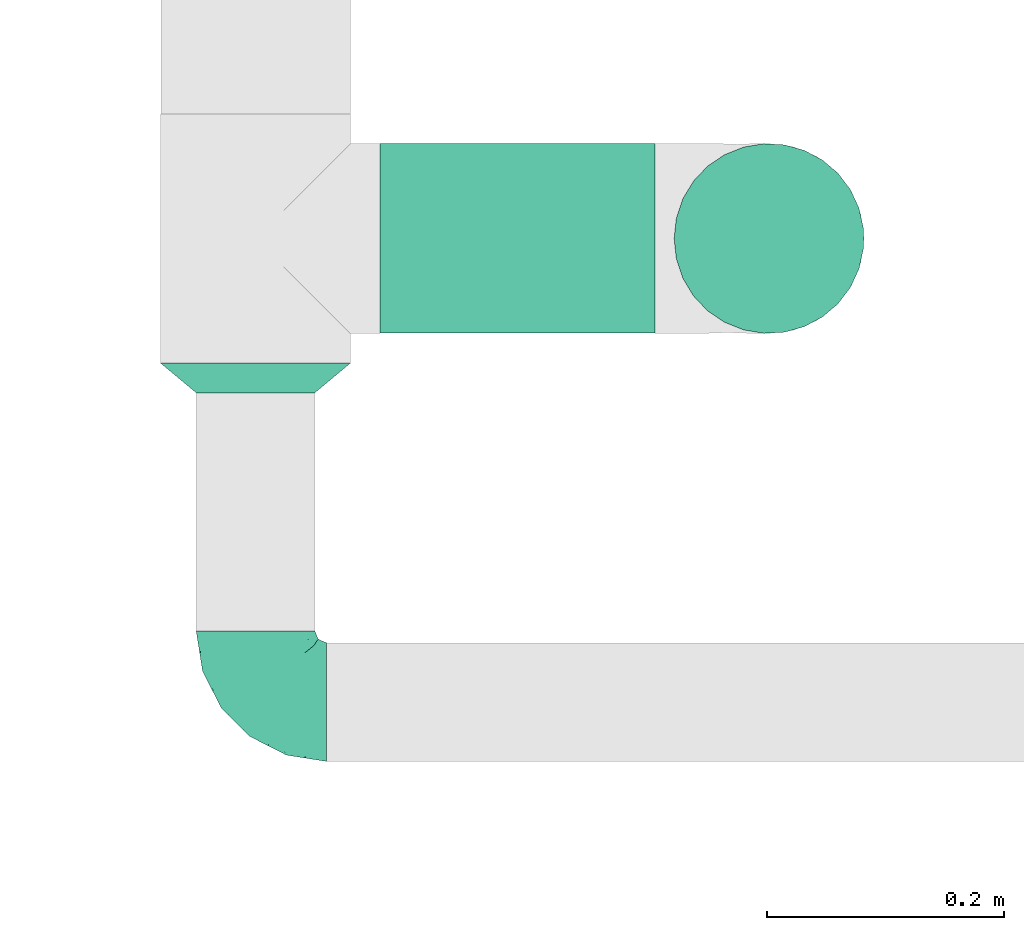
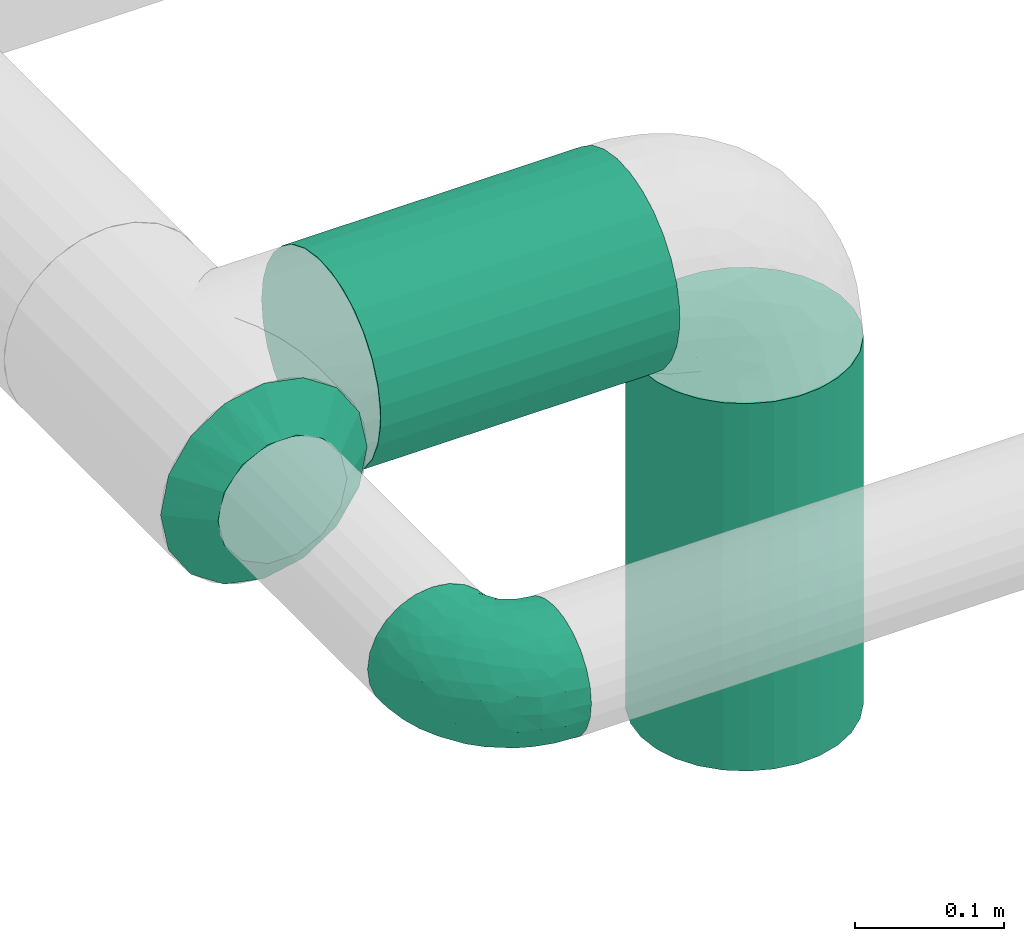
# One storey, part 2 of 12: 2 flow fittings, 2 flow segments.
"""IFC2X3 building model written with IfcOpenShell, lengths in millimetres."""

from ifc_helpers import new_model, entity, si_unit, converted_unit, derived_unit, direction, frame, frame_2d, origin, origin_2d_with_axis, place, context, subcontext, project, spatial, circle, extrude, faceted_brep, source, transform, mapped, material, type_object, type_shapes, element, save


model = new_model("IFC2X3")

# Units and contexts
model_context = context("Model", 3, precision=0.01, world=origin(), true_north=direction((6.12303176911189e-17, 1.0)))
body_context = subcontext(model_context, "Body", "Model", "MODEL_VIEW")
ifc_project = project(units=[si_unit("LENGTHUNIT", "METRE", prefix="MILLI"), si_unit("AREAUNIT", "SQUARE_METRE"), si_unit("VOLUMEUNIT", "CUBIC_METRE"), converted_unit("PLANEANGLEUNIT", "DEGREE", entity("IfcRatioMeasure", 0.0174532925199433), si_unit("PLANEANGLEUNIT", "RADIAN"), dimensions=[0, 0, 0, 0, 0, 0, 0]), si_unit("MASSUNIT", "GRAM", prefix="KILO"), derived_unit("MASSDENSITYUNIT", [(si_unit("MASSUNIT", "GRAM", prefix="KILO"), 1), (si_unit("LENGTHUNIT", "METRE"), -3)]), si_unit("TIMEUNIT", "SECOND"), si_unit("FREQUENCYUNIT", "HERTZ"), si_unit("THERMODYNAMICTEMPERATUREUNIT", "DEGREE_CELSIUS"), derived_unit("THERMALTRANSMITTANCEUNIT", [(si_unit("MASSUNIT", "GRAM", prefix="KILO"), 1), (si_unit("THERMODYNAMICTEMPERATUREUNIT", "KELVIN"), -1), (si_unit("TIMEUNIT", "SECOND"), -3)]), derived_unit("VOLUMETRICFLOWRATEUNIT", [(si_unit("LENGTHUNIT", "METRE"), 3), (si_unit("TIMEUNIT", "SECOND"), -1)]), si_unit("ELECTRICCURRENTUNIT", "AMPERE"), si_unit("ELECTRICVOLTAGEUNIT", "VOLT"), si_unit("POWERUNIT", "WATT"), si_unit("FORCEUNIT", "NEWTON", prefix="KILO"), si_unit("ILLUMINANCEUNIT", "LUX"), si_unit("LUMINOUSFLUXUNIT", "LUMEN"), si_unit("LUMINOUSINTENSITYUNIT", "CANDELA"), derived_unit("USERDEFINED", [(si_unit("MASSUNIT", "GRAM", prefix="KILO"), -1), (si_unit("LENGTHUNIT", "METRE"), -2), (si_unit("TIMEUNIT", "SECOND"), 3), (si_unit("LUMINOUSFLUXUNIT", "LUMEN"), 1)]), derived_unit("LINEARVELOCITYUNIT", [(si_unit("LENGTHUNIT", "METRE"), 1), (si_unit("TIMEUNIT", "SECOND"), -1)]), si_unit("PRESSUREUNIT", "PASCAL"), derived_unit("USERDEFINED", [(si_unit("LENGTHUNIT", "METRE"), -2), (si_unit("MASSUNIT", "GRAM", prefix="KILO"), 1), (si_unit("TIMEUNIT", "SECOND"), -2)])], contexts=[model_context])

# Site, building, storey
site_placement = place(None, origin())
site = spatial("IfcSite", under=ifc_project, at=site_placement, CompositionType="ELEMENT")
building_placement = place(site_placement, origin())
building = spatial("IfcBuilding", under=site, at=building_placement, CompositionType="ELEMENT")
storey_placement = place(building_placement, frame((0.0, 0.0, 4000.0)))
storey = spatial("IfcBuildingStorey", under=building, at=storey_placement, Name="01 Level", CompositionType="ELEMENT", Elevation=4000.0)

# Flow segments
duct_segment_type = type_object("IfcDuctSegmentType", Name="Round Duct:Air", PredefinedType="NOTDEFINED")
flow_segment_1_placement = place(storey_placement, frame((23290.9900708518, -69876.8295037279, 2918.40472776409)))
element("IfcFlowSegment", 1, at=flow_segment_1_placement, inside=storey, type_object=duct_segment_type, Name="Round Duct:Air", ObjectType="Round Duct:Air", context=body_context, shape_type="SweptSolid", body=[
    extrude(circle(Radius=80.0, at=frame_2d((0.0, 1.08286712929839e-12), x_axis=(1.0, 0.0))), frame((0.0, 81.595272235915, 81.595272235915), z_axis=(1.0, 0.0, 0.0), x_axis=(0.0, 1.0, 0.0)), (0.0, 0.0, 1.0), 231.770344008329),
])
flow_segment_2_placement = place(storey_placement, frame((23537.1651426242, -69876.8295037279, 2603.07847999999)))
element("IfcFlowSegment", 2, at=flow_segment_2_placement, inside=storey, type_object=duct_segment_type, Name="Round Duct:Air", ObjectType="Round Duct:Air", context=body_context, shape_type="SweptSolid", body=[
    extrude(circle(Radius=79.9999999999999, at=origin_2d_with_axis()), frame((81.595272235915, 81.595272235915, 0.0), z_axis=(0.0, 0.0, 1.0), x_axis=(-1.0, 0.0, 0.0)), (0.0, 0.0, 1.0), 300.921520000008),
])

# Flow fittings
duct_fitting_type_1 = type_object("IfcDuctFittingType", Name="Air_Elbow short_Circ", PredefinedType="NOTDEFINED")
shared_shape_1 = source(origin(), body_context, "Body", "Brep", [
    faceted_brep([(-60.0, 0.0, -50.0), (-60.0, -12.9409522551259, -48.2962913144534), (-60.0, -25.0, -43.3012701892219), (-60.0, -35.3553390593273, -35.3553390593274), (-60.0, -43.3012701892218, -25.0), (-60.0, -48.2962913144533, -12.9409522551262), (-60.0, -50.0, 0.0), (-60.0, -48.2962913144534, 12.9409522551259), (-60.0, -43.301270189222, 25.0), (-60.0, -35.3553390593275, 35.3553390593272), (-60.0, -25.0, 43.3012701892218), (-60.0, -12.9409522551262, 48.2962913144533), (-60.0, 0.0, 50.0), (-60.0, 12.9409522551258, 48.2962913144534), (-60.0, 18.9704761275628, 45.7987807518377), (-60.0, 25.0, 43.301270189222), (-60.0, 35.3553390593271, 35.3553390593275), (-60.0, 43.3012701892217, 25.0), (-60.0, 48.2962913144533, 12.9409522551263), (-60.0, 50.0, 0.0), (-60.0, 48.2962913144534, -12.940952255126), (-60.0, 43.3012701892219, -25.0), (-60.0, 35.3553390593274, -35.3553390593273), (-60.0, 25.0, -43.3012701892219), (-60.0, 12.9409522551261, -48.2962913144533), (-12.9409522551252, 60.0, -48.2962913144533), (-18.9704761275622, 60.0, -45.7987807518376), (-25.0, 60.0, -43.3012701892219), (-35.3553390593265, 60.0, -35.3553390593273), (-43.301270189221, 60.0, -25.0), (-48.2962913144525, 60.0, -12.940952255126), (-50.0, 60.0, 0.0), (-48.2962913144524, 60.0, 12.9409522551263), (-43.3012701892209, 60.0, 25.0), (-35.3553390593263, 60.0, 35.3553390593275), (-25.0, 60.0, 43.301270189222), (-12.9409522551249, 60.0, 48.2962913144534), (0.0, 60.0, 50.0), (12.9409522551271, 60.0, 48.2962913144533), (25.0, 60.0, 43.3012701892218), (35.3553390593284, 60.0, 35.3553390593272), (43.3012701892229, 60.0, 25.0), (48.2962913144543, 60.0, 12.9409522551259), (50.0, 60.0, 0.0), (48.2962913144542, 60.0, -12.9409522551262), (43.3012701892227, 60.0, -25.0), (35.3553390593281, 60.0, -35.3553390593274), (25.0, 60.0, -43.3012701892219), (12.9409522551268, 60.0, -48.2962913144534), (0.0, 60.0, -50.0), (-49.0564079906538, -40.7801415025898, 28.076858272246), (-41.7413930879589, -46.3367006663211, 14.3622192349088), (-34.4613055182162, -40.2781615499549, 24.6893391361235), (-43.0040653093767, -47.3081083962334, 0.0), (-49.945230570524, 14.009456366224, 48.3010541644054), (-46.9531334224505, 28.9691372331723, 42.5007483631415), (46.3367008388525, 41.7413924405609, 14.3622183025403), (-20.8886043148544, -37.032907476011, 22.5646988156665), (-16.4026032888538, -28.8335615486346, 31.3447155376829), (-28.9195822317624, -34.3595042325614, 30.8522337271345), (18.1051423029501, 18.6630708487668, 41.1725129713058), (21.5851347328685, 39.3600400603544, 43.7780030266717), (8.51327307359233, 29.8490270681828, 47.7425705251578), (-16.993357552601, 43.112835299455, 48.0588376259554), (-3.94145017646366, 44.1513377558611, 49.9695692624666), (-39.360041631582, -21.585137213725, 43.7780019122438), (-18.6630773197735, -18.1051465687322, 41.1725124591201), (-29.8490305613342, -8.51327565171467, 47.7425702287428), (-41.9572959526986, -32.3456520264411, 36.575294220854), (-28.3738768436699, -26.9110252548877, 38.0083212356069), (-51.9080682539527, 51.9080682564403, 11.9284381035673), (-47.8035915916317, 49.3365848090307, 24.1167211667097), (-28.9388870718402, 47.4392187660381, 42.4028289139121), (-46.4119732313288, -8.97786791845547, 48.9268647037242), (-0.0901680697707372, -16.249793899354, 33.6631038709893), (12.7026747916207, -16.0653579926251, 21.330563165355), (15.3655862372502, -1.44443599762982, 33.3656926605527), (-40.3512409746586, 17.2001159603688, 48.3058104561749), (-43.5357165770215, 3.92607608695299, 49.9756911723036), (-26.0984306641832, 9.4519602521943, 49.9925353018775), (-51.5116032222349, 38.9116886125261, 33.3337470302399), (32.3456522233896, 41.9572963751397, 36.5752941161915), (34.3595052098631, 28.9195768148052, 30.852230382061), (40.2781623134548, 34.4613024546835, 24.689336501659), (-52.6192947824697, 44.3162483434043, 26.0687788699409), (8.97786691245749, 46.4119718726044, 48.9268648562795), (35.0507691245895, 17.8379542600364, 23.7817320689175), (-10.9191638901366, -35.9593562872322, 14.7243484546897), (0.164802122834046, -30.9507973718637, 9.70158150296541), (-0.154113830211583, -27.0441585303382, 20.4371969134619), (40.7801421145919, 49.0564069362065, 28.0768572079665), (42.5446020921407, 25.3772134428819, 13.1791087429088), (10.303795037543, -23.1674391280597, 10.425151792526), (23.1044280783399, -10.2139010010231, 10.911201952746), (44.6162167924678, 26.008130618756, 0.0), (47.3081083962343, 43.0040653093781, 0.0), (-41.6246972537655, 41.624696659769, 36.6481760707585), (-32.7984308187714, 33.1644722725009, 45.0025999357929), (-7.74597844975689, 15.8760781607658, 49.2907901610601), (-16.0198594588589, 0.790040969679908, 48.0702532559686), (-10.2505184648613, 32.0701285913551, 49.9130990257927), (-52.9289321881336, 52.9289321881345, 0.0), (-38.9116885130941, 51.5116028691678, 33.3337472807585), (28.8335585354312, 16.4025932897411, 31.3447134244473), (27.3373523634918, 28.9262874076833, 37.8242669720924), (-10.6758764332908, -36.8040430868554, 0.0), (-21.0820556464647, 25.013405385062, 49.4085637061446), (-25.3772163464242, -42.5446022063287, 13.179111746218), (-29.4708300504911, 18.1716321771538, 49.3204506255928), (-0.613576836584022, 32.0726800049485, 49.6825501479137), (-26.0081306187546, -44.6162167924668, 0.0), (7.809323786389, 12.5506490133832, 44.518448707346), (-1.21981718883359, 1.21981162112378, 44.3295369128094), (4.65637775217312, -28.991869381244, 0.0), (25.4694098156993, -0.899564345657441, 21.9045256717261), (30.9271083665945, -0.192011278925337, 9.72551394481069), (36.8040430868565, 10.6758764332921, 0.0), (8.17237141004653, 0.709602060124845, 39.7363553078916), (-1.20691178924098, -8.42774890414073, 39.8368437988478), (-11.8311378719951, -8.12805454147699, 44.1670059112514), (16.8241235667092, -16.8241235667079, 0.0), (35.9593546638031, 10.9191599029529, 14.7243472530362), (28.9918693812452, -4.65637775217184, 0.0), (-14.0094588862512, 49.9452236085703, -48.3010539035587), (-41.7413926252934, -46.3367005832334, -14.3622192468898), (-34.4613048910139, -40.2781614393135, -24.6893390523416), (-25.3772156484835, -42.5446019119684, -13.1791119497906), (-43.1128355702084, 16.9933564311214, -48.0588378972243), (-44.1513388294639, 3.94144876101963, -49.969569299814), (-49.3365851024771, 47.8035917204495, -24.1167206397972), (-41.62469790636, 41.6246960630329, -36.6481760341003), (-51.5116035577561, 38.9116884747343, -33.3337470330805), (23.1674375203698, -10.3037953844737, -10.4251565011195), (10.2138986720569, -23.1044286164337, -10.9112068363266), (16.0653446591387, -12.7026862735946, -21.330566780897), (35.9593546209329, 10.9191616413996, -14.7243499458666), (30.9507965291521, -0.164803474452689, -9.70158128624016), (27.0441512446144, 0.154114142874967, -20.4372107139949), (-18.6630757642047, -18.1051470727615, -41.1725116507822), (-16.4026019873643, -28.8335613017021, -31.344715100551), (-28.9262923378956, -27.3373567288812, -37.8242648451571), (-15.8760743141415, 7.74597807562093, -49.2907896898935), (-9.45196719952168, 26.0984311316614, -49.9925354060889), (-0.79004904716724, 16.0198534732482, -48.0702540902608), (-25.0134056140136, 21.0820528609103, -49.4085640038716), (-49.0564077792961, -40.7801415002595, -28.0768582420378), (-47.4392196421628, 28.9388866268174, -42.4028289664685), (-33.1644687800828, 32.7984277324913, -45.0026021871039), (-51.9080682748156, 51.9080682458111, -11.9284380741106), (-41.9572952892088, -32.3456521258773, -36.5752940113004), (-39.3600407942016, -21.5851376014369, -43.7780015915287), (-29.8490289400598, -8.5132766456386, -47.7425697425162), (-46.411972568153, -8.97786849540185, -48.9268645575236), (-28.9195813138317, -34.3595041939927, -30.8522334076151), (-17.8379596675892, -35.0507702162708, -23.7817342784206), (21.5851368100191, 39.3600388626355, -43.7780017534797), (26.9110256448416, 28.3738769796432, -38.0083209621406), (18.1051443153088, 18.6630730295509, -41.1725124486671), (-38.911688364674, 51.5116023985273, -33.3337476311683), (-44.316248159738, 52.6192941440622, -26.0687795868405), (-17.2001201011705, 40.3512365316697, -48.3058099460363), (-3.92607321834031, 43.5357049838062, -49.9756913600445), (8.51327412363391, 29.8490256018375, -47.7425700423665), (8.97786798225732, 46.4119703958823, -48.9268645751331), (40.7801413413476, 49.0564079294803, -28.0768584987253), (-28.969136268001, 46.9531365639949, -42.5007481599507), (16.2497893015437, 0.0901603719773552, -33.6631026184802), (1.44442453081588, -15.3655954628303, -33.3656927670723), (32.3456517066656, 41.9572939682546, -36.5752941586943), (46.3367004266908, 41.7413922128929, -14.3622195286513), (34.3595039081184, 28.9195810717321, -30.8522336573022), (37.0329066484517, 20.888602858321, -22.564699256686), (28.8335602968518, 16.402602640196, -31.3447165791004), (40.2781610753798, 34.461304879185, -24.6893396682814), (-32.0701289123428, 10.2505155181949, -49.9130991682027), (42.5446013435109, 25.3772148558883, -13.1791129929581), (-18.17163862849, 29.4708285244359, -49.3204499074468), (-32.0726819537407, 0.61357350659226, -49.6825499006192), (-12.5506417422758, -7.80933382246174, -44.5184423716321), (-1.21981337419447, 1.21981084831843, -44.3295352204376), (0.899550937376629, -25.4694163362272, -21.9045307406697), (0.192009591001318, -30.9271092740971, -9.72551482732434), (-0.709596078235449, -8.17237239935393, -39.7363517396473), (8.42775025848031, 1.2069144200305, -39.8368443201002), (8.12805004108825, 11.8311369938791, -44.1670075921659), (-10.9191629014402, -35.9593557213529, -14.724348628576)], [[[0, 1, 2, 3, 4, 5, 6, 7, 8, 9, 10, 11, 12, 13, 14, 15, 16, 17, 18, 19, 20, 21, 22, 23, 24]], [[25, 26, 27, 28, 29, 30, 31, 32, 33, 34, 35, 36, 37, 38, 39, 40, 41, 42, 43, 44, 45, 46, 47, 48, 49]], [[50, 51, 52]], [[53, 7, 6]], [[54, 55, 15]], [[41, 56, 42]], [[57, 58, 59]], [[60, 61, 62]], [[36, 63, 64]], [[65, 66, 67]], [[10, 68, 65]], [[59, 69, 68]], [[70, 71, 32]], [[9, 8, 50]], [[35, 72, 63]], [[12, 11, 73]], [[74, 75, 76]], [[15, 14, 13, 54]], [[77, 78, 79]], [[11, 10, 65]], [[51, 8, 7]], [[16, 80, 17]], [[81, 82, 83]], [[80, 84, 17]], [[15, 55, 16]], [[35, 34, 72]], [[18, 70, 19]], [[65, 67, 73]], [[38, 37, 85]], [[84, 18, 17]], [[61, 38, 85]], [[82, 86, 83]], [[87, 88, 89]], [[38, 61, 39]], [[40, 90, 41]], [[64, 37, 36]], [[56, 83, 91]], [[56, 41, 90]], [[61, 81, 39]], [[92, 93, 75]], [[56, 94, 95]], [[72, 96, 97]], [[98, 79, 99]], [[100, 64, 63]], [[101, 19, 70]], [[10, 9, 68]], [[101, 70, 31]], [[65, 69, 66]], [[96, 102, 71]], [[60, 103, 104]], [[33, 102, 34]], [[88, 87, 105]], [[33, 32, 71]], [[63, 72, 97]], [[98, 106, 79]], [[36, 35, 63]], [[13, 12, 78]], [[107, 87, 57]], [[81, 40, 39]], [[83, 86, 91]], [[7, 53, 51]], [[95, 42, 56]], [[73, 78, 12]], [[108, 79, 106]], [[77, 108, 97]], [[80, 55, 96]], [[102, 72, 34]], [[96, 55, 97]], [[100, 63, 106]], [[64, 109, 85]], [[104, 81, 61]], [[90, 81, 83]], [[50, 68, 9]], [[59, 68, 52]], [[78, 67, 79]], [[110, 51, 53]], [[43, 42, 95]], [[99, 79, 67]], [[111, 98, 112]], [[100, 109, 64]], [[52, 51, 107]], [[88, 113, 92]], [[114, 93, 115]], [[103, 60, 76]], [[103, 76, 114]], [[116, 94, 91]], [[112, 117, 111]], [[76, 75, 114]], [[112, 118, 117]], [[119, 118, 112]], [[74, 66, 58]], [[99, 119, 112]], [[74, 58, 89]], [[76, 117, 118]], [[77, 97, 55]], [[63, 97, 106]], [[92, 113, 120]], [[114, 121, 86]], [[115, 93, 122]], [[122, 93, 120]], [[75, 93, 114]], [[93, 92, 120]], [[92, 75, 89]], [[74, 89, 75]], [[57, 89, 58]], [[64, 85, 37]], [[61, 85, 62]], [[65, 73, 11]], [[78, 73, 67]], [[51, 110, 107]], [[115, 116, 121]], [[91, 121, 116]], [[94, 56, 91]], [[71, 102, 33]], [[72, 102, 96]], [[55, 80, 16]], [[84, 96, 71]], [[106, 98, 100]], [[109, 98, 62]], [[98, 109, 100]], [[85, 109, 62]], [[89, 88, 92]], [[107, 105, 87]], [[96, 84, 80]], [[84, 71, 70]], [[70, 18, 84]], [[31, 70, 32]], [[51, 50, 8]], [[68, 50, 52]], [[81, 90, 40]], [[56, 90, 83]], [[54, 78, 77]], [[78, 54, 13]], [[54, 77, 55]], [[60, 104, 61]], [[82, 104, 103]], [[104, 82, 81]], [[86, 82, 103]], [[114, 86, 103]], [[86, 121, 91]], [[57, 59, 52]], [[69, 59, 58]], [[66, 69, 58]], [[68, 69, 65]], [[107, 57, 52]], [[57, 87, 89]], [[97, 108, 106]], [[77, 79, 108]], [[119, 67, 66]], [[98, 99, 112]], [[67, 119, 99]], [[118, 66, 74]], [[66, 118, 119]], [[76, 118, 74]], [[76, 60, 117]], [[111, 117, 60]], [[60, 62, 111]], [[98, 111, 62]], [[105, 107, 110]], [[113, 88, 105]], [[116, 115, 122]], [[114, 115, 121]], [[123, 27, 26, 25]], [[124, 125, 126]], [[23, 127, 24]], [[0, 24, 128]], [[129, 130, 131]], [[132, 133, 134]], [[21, 131, 22]], [[135, 136, 137]], [[21, 20, 129]], [[138, 139, 140]], [[141, 142, 143]], [[144, 142, 141]], [[124, 4, 145]], [[146, 130, 147]], [[124, 110, 53]], [[148, 129, 20]], [[149, 2, 150]], [[138, 150, 151]], [[1, 150, 2]], [[127, 146, 147]], [[23, 22, 146]], [[145, 4, 3]], [[3, 2, 149]], [[1, 152, 150]], [[153, 154, 125]], [[149, 153, 125]], [[19, 101, 148]], [[125, 154, 126]], [[31, 30, 148]], [[155, 156, 157]], [[29, 158, 159]], [[48, 47, 155]], [[136, 135, 116]], [[28, 158, 29]], [[146, 127, 23]], [[160, 161, 142]], [[155, 162, 163]], [[46, 45, 164]], [[28, 27, 165]], [[166, 134, 167]], [[48, 163, 49]], [[168, 155, 47]], [[24, 127, 128]], [[169, 45, 44]], [[170, 171, 172]], [[162, 155, 157]], [[1, 0, 152]], [[173, 164, 169]], [[25, 49, 161]], [[43, 95, 44]], [[47, 46, 168]], [[174, 128, 127]], [[170, 156, 168]], [[123, 165, 27]], [[4, 124, 5]], [[44, 95, 169]], [[148, 20, 19]], [[175, 135, 171]], [[159, 30, 29]], [[53, 5, 124]], [[163, 161, 49]], [[176, 142, 144]], [[160, 176, 147]], [[158, 165, 130]], [[131, 146, 22]], [[130, 165, 147]], [[174, 127, 144]], [[128, 177, 152]], [[140, 149, 150]], [[145, 149, 125]], [[164, 168, 46]], [[170, 168, 173]], [[161, 162, 142]], [[94, 169, 95]], [[6, 5, 53]], [[143, 142, 162]], [[178, 141, 179]], [[174, 177, 128]], [[173, 169, 175]], [[136, 122, 132]], [[180, 133, 181]], [[139, 138, 167]], [[139, 167, 180]], [[105, 110, 126]], [[179, 182, 178]], [[167, 134, 180]], [[179, 183, 182]], [[184, 183, 179]], [[166, 157, 172]], [[143, 184, 179]], [[166, 172, 137]], [[167, 182, 183]], [[160, 147, 165]], [[127, 147, 144]], [[132, 122, 120]], [[180, 185, 154]], [[181, 133, 113]], [[113, 133, 120]], [[134, 133, 180]], [[133, 132, 120]], [[132, 134, 137]], [[166, 137, 134]], [[171, 137, 172]], [[128, 152, 0]], [[150, 152, 151]], [[155, 163, 48]], [[161, 163, 162]], [[169, 94, 175]], [[181, 105, 185]], [[126, 185, 105]], [[110, 124, 126]], [[129, 131, 21]], [[146, 131, 130]], [[165, 158, 28]], [[159, 130, 129]], [[144, 141, 174]], [[177, 141, 151]], [[141, 177, 174]], [[152, 177, 151]], [[137, 136, 132]], [[175, 116, 135]], [[130, 159, 158]], [[159, 129, 148]], [[31, 148, 101]], [[148, 30, 159]], [[169, 164, 45]], [[168, 164, 173]], [[149, 145, 3]], [[124, 145, 125]], [[123, 161, 160]], [[161, 123, 25]], [[123, 160, 165]], [[138, 140, 150]], [[153, 140, 139]], [[140, 153, 149]], [[154, 153, 139]], [[180, 154, 139]], [[154, 185, 126]], [[171, 170, 173]], [[156, 170, 172]], [[157, 156, 172]], [[168, 156, 155]], [[175, 171, 173]], [[171, 135, 137]], [[147, 176, 144]], [[160, 142, 176]], [[184, 162, 157]], [[141, 143, 179]], [[162, 184, 143]], [[183, 157, 166]], [[157, 183, 184]], [[167, 183, 166]], [[167, 138, 182]], [[178, 182, 138]], [[138, 151, 178]], [[141, 178, 151]], [[116, 175, 94]], [[122, 136, 116]], [[105, 181, 113]], [[180, 181, 185]]]),
])
type_shapes(duct_fitting_type_1, [shared_shape_1])
flow_fitting_1_placement = place(storey_placement, frame((23185.9900708518, -70185.9356124915, 3000.0), z_axis=(0.0, 0.0, 1.0), x_axis=(0.0, -1.0, 0.0)))
element("IfcFlowFitting", 3, at=flow_fitting_1_placement, inside=storey, type_object=duct_fitting_type_1, Name="elbow_short_001:Air_Elbow short_Circ", ObjectType="elbow_short_001:Air_Elbow short_Circ", context=body_context, shape_type="MappedRepresentation", body=[
    mapped(shared_shape_1, transform((0.0, 0.0, 0.0), scale=1.0)),
])
ifc_material = material(Name="Material_Duct")
duct_fitting_type_2 = type_object("IfcDuctFittingType", Name="Air_Reduction_Circ", PredefinedType="NOTDEFINED", material=ifc_material)
shared_shape_2 = source(origin(), body_context, "Body", "Brep", [
    faceted_brep([(25.0, -50.0, 0.0), (25.0, -47.5242216975607, -10.8470934779334), (25.0, -45.0484433951223, -21.6941869558729), (25.0, -38.1114667440304, -30.3928805396358), (25.0, -31.1744900929385, -39.0915741233988), (25.0, -21.1502683953773, -43.9189848662444), (25.0, -11.1260466978161, -48.74639560909), (25.0, 0.0, -48.7463956090899), (25.0, 11.1260466978174, -48.7463956090898), (25.0, 21.1502683953783, -43.9189848662439), (25.0, 31.1744900929393, -39.0915741233981), (25.0, 38.1114667440309, -30.3928805396354), (25.0, 45.0484433951224, -21.6941869558726), (25.0, 47.5242216975608, -10.8470934779335), (25.0, 50.0, 0.0), (25.0, 47.5242216975603, 10.8470934779443), (25.0, 45.0484433951197, 21.6941869558827), (25.0, 38.1114667440274, 30.3928805396434), (25.0, 31.1744900929351, 39.0915741234041), (25.0, 21.1502683953754, 43.9189848662482), (25.0, 11.1260466978156, 48.7463956090923), (25.0, 0.0, 48.7463956090925), (25.0, -11.1260466978137, 48.7463956090927), (25.0, -21.1502683953737, 43.9189848662489), (25.0, -31.1744900929338, 39.0915741234051), (25.0, -38.1114667440265, 30.3928805396443), (25.0, -45.0484433951193, 21.6941869558836), (25.0, -47.5242216975601, 10.8470934779448), (0.0, 80.0, 0.0), (0.0, 76.9551813004502, -15.3073372946042), (0.0, 73.9103626009034, -30.6146745892079), (0.0, 65.2394525479148, -43.5916085420674), (0.0, 56.5685424949263, -56.568542494927), (0.0, 43.5916085420678, -65.239452547918), (0.0, 30.6146745892093, -73.9103626009091), (0.0, 15.3073372946045, -76.9551813004584), (0.0, 0.0, -80.0), (0.0, -15.3073372946054, -76.9551813004588), (0.0, -30.6146745892104, -73.9103626009099), (0.0, -43.5916085420694, -65.2394525479189), (0.0, -56.5685424949284, -56.5685424949279), (0.0, -65.2394525479173, -43.5916085420681), (0.0, -73.9103626009062, -30.6146745892082), (0.0, -76.9551813004531, -15.307337294604), (0.0, -80.0, 0.0), (0.0, -76.9551813004526, 15.3073372946037), (0.0, -73.9103626009022, 30.6146745892071), (0.0, -65.2394525479115, 43.5916085420641), (0.0, -56.5685424949208, 56.5685424949211), (0.0, -43.5916085420627, 65.2394525479091), (0.0, -30.6146745892045, 73.910362600897), (0.0, -15.3073372946022, 76.9551813004446), (0.0, 0.0, 80.0), (0.0, 15.3073372946022, 76.955181300444), (0.0, 30.6146745892043, 73.9103626008959), (0.0, 43.5916085420619, 65.2394525479076), (0.0, 56.5685424949195, 56.5685424949194), (0.0, 65.2394525479096, 43.5916085420626), (0.0, 73.9103626008998, 30.6146745892058), (0.0, 76.9551813004499, 15.3073372946029)], [[[0, 1, 2, 3, 4, 5, 6, 7, 8, 9, 10, 11, 12, 13, 14, 15, 16, 17, 18, 19, 20, 21, 22, 23, 24, 25, 26, 27]], [[28, 29, 30, 31, 32, 33, 34, 35, 36, 37, 38, 39, 40, 41, 42, 43, 44, 45, 46, 47, 48, 49, 50, 51, 52, 53, 54, 55, 56, 57, 58, 59]], [[12, 30, 13]], [[33, 9, 34]], [[31, 30, 12]], [[41, 40, 3]], [[6, 37, 7]], [[7, 35, 8]], [[4, 40, 39]], [[12, 11, 31]], [[14, 29, 28]], [[36, 7, 37]], [[9, 33, 10]], [[14, 13, 29]], [[34, 9, 8]], [[5, 4, 39]], [[0, 43, 1]], [[41, 2, 42]], [[6, 38, 37]], [[11, 32, 31]], [[11, 10, 32]], [[5, 38, 6]], [[39, 38, 5]], [[2, 41, 3]], [[13, 30, 29]], [[40, 4, 3]], [[1, 42, 2]], [[35, 34, 8]], [[43, 0, 44]], [[35, 7, 36]], [[43, 42, 1]], [[33, 32, 10]], [[26, 46, 27]], [[49, 23, 50]], [[47, 46, 26]], [[57, 56, 17]], [[20, 53, 21]], [[21, 51, 22]], [[18, 56, 55]], [[26, 25, 47]], [[0, 45, 44]], [[52, 21, 53]], [[23, 49, 24]], [[0, 27, 45]], [[50, 23, 22]], [[19, 18, 55]], [[14, 59, 15]], [[57, 16, 58]], [[20, 54, 53]], [[25, 48, 47]], [[25, 24, 48]], [[19, 54, 20]], [[55, 54, 19]], [[16, 57, 17]], [[27, 46, 45]], [[56, 18, 17]], [[15, 58, 16]], [[51, 50, 22]], [[59, 14, 28]], [[51, 21, 52]], [[59, 58, 15]], [[49, 48, 24]]]),
])
type_shapes(duct_fitting_type_2, [shared_shape_2])
flow_fitting_2_placement = place(storey_placement, frame((23185.9900708518, -69900.234231492, 3000.0), z_axis=(0.0, 0.0, 1.0), x_axis=(0.0, -1.0, 0.0)))
element("IfcFlowFitting", 4, at=flow_fitting_2_placement, inside=storey, type_object=duct_fitting_type_2, material=ifc_material, Name="reduction_001:Air_Reduction_Circ", ObjectType="reduction_001:Air_Reduction_Circ", context=body_context, shape_type="MappedRepresentation", body=[
    mapped(shared_shape_2, transform((0.0, 0.0, 0.0), scale=1.0)),
])

save(model, "model.ifc")
